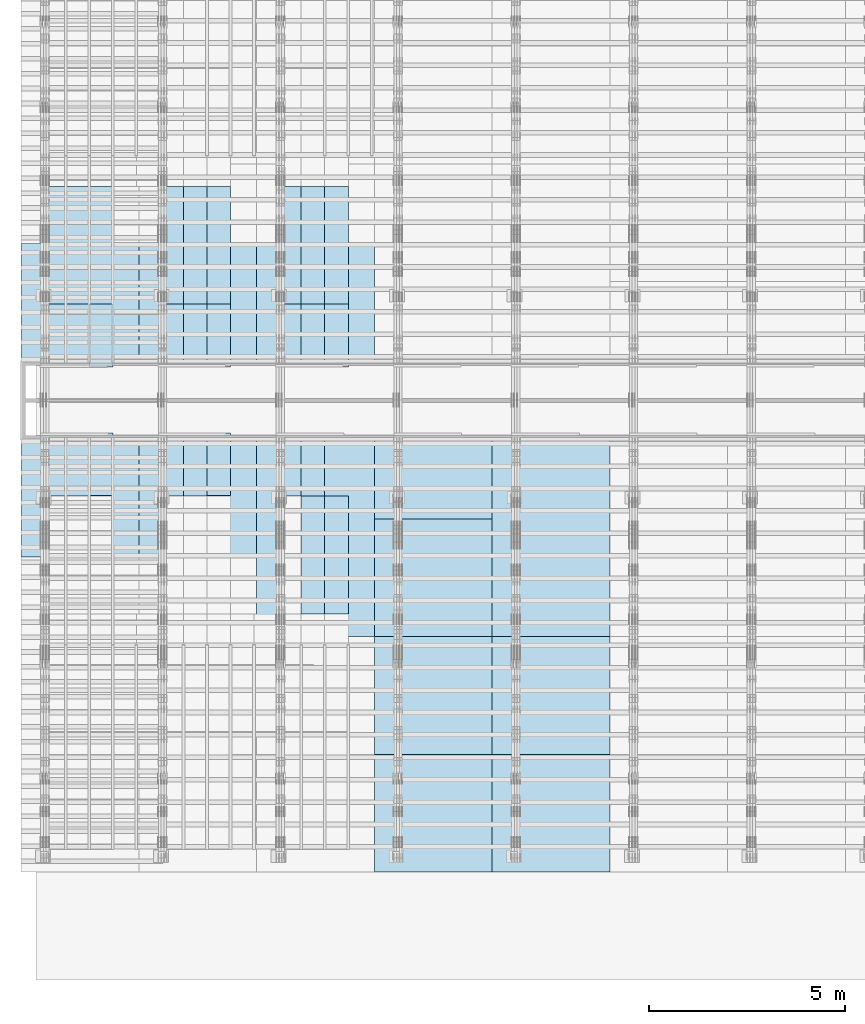
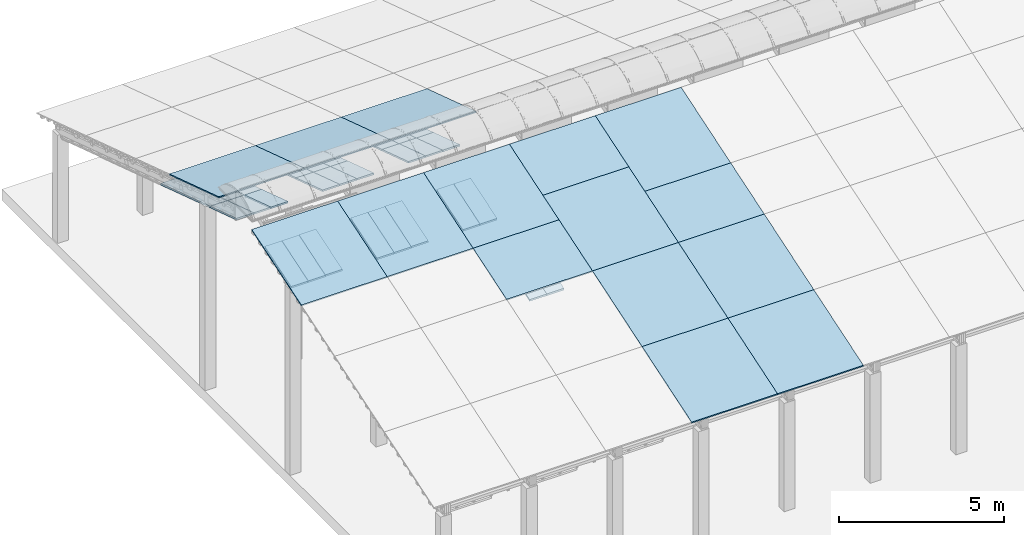
# One storey, part 6 of 385: 44 slabs, 44 elements without a shape of their own.
"""IFC2X3 building model written with IfcOpenShell, lengths in millimetres."""

from ifc_helpers import new_model, entity, si_unit, converted_unit, derived_unit, direction, frame, frame_2d, origin, place, context, subcontext, project, spatial, rectangle, extrude, material, layer, layer_set, element, aggregate, save


model = new_model("IFC2X3")

# Units and contexts
model_context = context("Model", 3, precision=0.01, world=origin(), true_north=direction((6.12303176911189e-17, 1.0)))
body_context = subcontext(model_context, "Body", "Model", "MODEL_VIEW")
ifc_project = project(units=[si_unit("LENGTHUNIT", "METRE", prefix="MILLI"), si_unit("AREAUNIT", "SQUARE_METRE"), si_unit("VOLUMEUNIT", "CUBIC_METRE"), converted_unit("PLANEANGLEUNIT", "DEGREE", entity("IfcRatioMeasure", 0.0174532925199433), si_unit("PLANEANGLEUNIT", "RADIAN"), dimensions=[0, 0, 0, 0, 0, 0, 0]), si_unit("MASSUNIT", "GRAM", prefix="KILO"), derived_unit("MASSDENSITYUNIT", [(si_unit("MASSUNIT", "GRAM", prefix="KILO"), 1), (si_unit("LENGTHUNIT", "METRE"), -3)]), si_unit("TIMEUNIT", "SECOND"), si_unit("FREQUENCYUNIT", "HERTZ"), si_unit("THERMODYNAMICTEMPERATUREUNIT", "DEGREE_CELSIUS"), derived_unit("THERMALTRANSMITTANCEUNIT", [(si_unit("MASSUNIT", "GRAM", prefix="KILO"), 1), (si_unit("THERMODYNAMICTEMPERATUREUNIT", "KELVIN"), -1), (si_unit("TIMEUNIT", "SECOND"), -3)]), derived_unit("VOLUMETRICFLOWRATEUNIT", [(si_unit("LENGTHUNIT", "METRE"), 3), (si_unit("TIMEUNIT", "SECOND"), -1)]), si_unit("ELECTRICCURRENTUNIT", "AMPERE"), si_unit("ELECTRICVOLTAGEUNIT", "VOLT"), si_unit("POWERUNIT", "WATT"), si_unit("FORCEUNIT", "NEWTON", prefix="KILO"), si_unit("ILLUMINANCEUNIT", "LUX"), si_unit("LUMINOUSFLUXUNIT", "LUMEN"), si_unit("LUMINOUSINTENSITYUNIT", "CANDELA"), derived_unit("USERDEFINED", [(si_unit("MASSUNIT", "GRAM", prefix="KILO"), -1), (si_unit("LENGTHUNIT", "METRE"), -2), (si_unit("TIMEUNIT", "SECOND"), 3), (si_unit("LUMINOUSFLUXUNIT", "LUMEN"), 1)]), derived_unit("LINEARVELOCITYUNIT", [(si_unit("LENGTHUNIT", "METRE"), 1), (si_unit("TIMEUNIT", "SECOND"), -1)]), si_unit("PRESSUREUNIT", "PASCAL"), derived_unit("USERDEFINED", [(si_unit("LENGTHUNIT", "METRE"), -2), (si_unit("MASSUNIT", "GRAM", prefix="KILO"), 1), (si_unit("TIMEUNIT", "SECOND"), -2)])], contexts=[model_context])

# Site, building, storey
site_placement = place(None, origin())
site = spatial("IfcSite", under=ifc_project, at=site_placement, CompositionType="ELEMENT")
building_placement = place(site_placement, origin())
building = spatial("IfcBuilding", under=site, at=building_placement, CompositionType="ELEMENT")
storey_placement = place(building_placement, origin())
storey = spatial("IfcBuildingStorey", under=building, at=storey_placement, Name="Default", CompositionType="ELEMENT", Elevation=0.0)

# Roof, slab
roof_1_placement = place(storey_placement, frame((-325.490958783843, 15713.9166481203, 3203.52447589904)))
roof_1 = element("IfcRoof", 1, at=roof_1_placement, inside=storey, ShapeType="NOTDEFINED")
ifc_material_1 = material()
ifc_layer_1 = layer(ifc_material_1, 40.0)
ifc_layer_set_1 = layer_set([ifc_layer_1])
slab_1_placement = place(roof_1_placement, origin())
slab_1 = element("IfcSlab", 2, at=slab_1_placement, material=ifc_layer_set_1, PredefinedType="ROOF", context=body_context, shape_type="SweptSolid", body=[
    extrude(rectangle(XDim=3154.3866727148, YDim=2999.99999999999, at=frame_2d((5.6843418860808e-13, 1.13686837721616e-12), x_axis=(0.0, 1.0))), frame((1500.0, 1500.0, 487.379544349359), z_axis=(0.0, 0.309016994374947, 0.951056516295154), x_axis=(1.0, 0.0, 0.0)), (0.0, -0.309016994374947, 0.951056516295154), 42.0584889695308),
])
aggregate(roof_1, [slab_1])

roof_2_placement = place(building_placement, frame((210.0, 17167.6676853402, 1763.02090616443)))
roof_2 = element("IfcRoof", 3, at=roof_2_placement, inside=storey, ShapeType="NOTDEFINED")
ifc_material_2 = material(Name="NLRS_n7_isolatie MegaPlus_Kingspan")
ifc_layer_2 = layer(ifc_material_2, 60.0)
ifc_layer_set_2 = layer_set([ifc_layer_2])
slab_2_placement = place(roof_2_placement, origin())
slab_2 = element("IfcSlab", 4, at=slab_2_placement, material=ifc_layer_set_2, PredefinedType="ROOF", context=body_context, shape_type="SweptSolid", body=[
    extrude(rectangle(XDim=600.0, YDim=3154.38667271481, at=frame_2d((0.0, 0.0), x_axis=(-1.0, 0.0))), frame((300.0, 1500.0, 487.379544349361), z_axis=(0.0, 0.309016994374947, 0.951056516295154), x_axis=(1.0, 0.0, 0.0)), (0.0, -0.309016994374947, 0.951056516295154), 63.087733454296),
])
aggregate(roof_2, [slab_2])

roof_3_placement = place(building_placement, frame((210.0, 15567.6676853402, 2737.77999486316)))
roof_3 = element("IfcRoof", 5, at=roof_3_placement, inside=storey, ShapeType="NOTDEFINED")
slab_3_placement = place(roof_3_placement, origin())
slab_3 = element("IfcSlab", 6, at=slab_3_placement, material=ifc_layer_set_2, PredefinedType="ROOF", context=body_context, shape_type="SweptSolid", body=[
    extrude(rectangle(XDim=600.0, YDim=1682.33955878123, at=frame_2d((-2.8421709430404e-14, 0.0), x_axis=(-1.0, 0.0))), frame((300.0, 800.0, 259.935756986325), z_axis=(0.0, 0.309016994374947, 0.951056516295154), x_axis=(1.0, 0.0, 0.0)), (0.0, -0.309016994374947, 0.951056516295154), 63.087733454296),
])
aggregate(roof_3, [slab_3])

roof_4_placement = place(storey_placement, frame((810.0, 17167.6676853402, 1763.02090616443)))
roof_4 = element("IfcRoof", 7, at=roof_4_placement, inside=storey, ShapeType="NOTDEFINED")
slab_4_placement = place(roof_4_placement, origin())
slab_4 = element("IfcSlab", 8, at=slab_4_placement, material=ifc_layer_set_2, PredefinedType="ROOF", context=body_context, shape_type="SweptSolid", body=[
    extrude(rectangle(XDim=600.0, YDim=3154.38667271481, at=frame_2d((0.0, 0.0), x_axis=(-1.0, 0.0))), frame((300.0, 1500.0, 487.379544349361), z_axis=(0.0, 0.309016994374947, 0.951056516295154), x_axis=(1.0, 0.0, 0.0)), (0.0, -0.309016994374947, 0.951056516295154), 63.087733454296),
])
aggregate(roof_4, [slab_4])

roof_5_placement = place(storey_placement, frame((810.0, 15567.6676853402, 2737.77999486316)))
roof_5 = element("IfcRoof", 9, at=roof_5_placement, inside=storey, ShapeType="NOTDEFINED")
slab_5_placement = place(roof_5_placement, origin())
slab_5 = element("IfcSlab", 10, at=slab_5_placement, material=ifc_layer_set_2, PredefinedType="ROOF", context=body_context, shape_type="SweptSolid", body=[
    extrude(rectangle(XDim=600.0, YDim=1682.33955878123, at=frame_2d((8.5265128291212e-14, 0.0), x_axis=(-1.0, 0.0))), frame((300.0, 800.0, 259.935756986325), z_axis=(0.0, 0.309016994374947, 0.951056516295154), x_axis=(1.0, 0.0, 0.0)), (0.0, -0.309016994374947, 0.951056516295154), 63.087733454296),
])
aggregate(roof_5, [slab_5])

roof_6_placement = place(storey_placement, frame((1410.0, 17167.6676853402, 1763.02090616443)))
roof_6 = element("IfcRoof", 11, at=roof_6_placement, inside=storey, ShapeType="NOTDEFINED")
slab_6_placement = place(roof_6_placement, origin())
slab_6 = element("IfcSlab", 12, at=slab_6_placement, material=ifc_layer_set_2, PredefinedType="ROOF", context=body_context, shape_type="SweptSolid", body=[
    extrude(rectangle(XDim=600.0, YDim=3154.38667271481, at=frame_2d((0.0, 0.0), x_axis=(-1.0, 0.0))), frame((300.0, 1500.0, 487.379544349361), z_axis=(0.0, 0.309016994374947, 0.951056516295154), x_axis=(1.0, 0.0, 0.0)), (0.0, -0.309016994374947, 0.951056516295154), 63.087733454296),
])
aggregate(roof_6, [slab_6])

roof_7_placement = place(storey_placement, frame((1410.0, 15565.4257355153, 2738.50844851925)))
roof_7 = element("IfcRoof", 13, at=roof_7_placement, inside=storey, ShapeType="NOTDEFINED")
slab_7_placement = place(roof_7_placement, origin())
slab_7 = element("IfcSlab", 14, at=slab_7_placement, material=ifc_layer_set_2, PredefinedType="ROOF", context=body_context, shape_type="SweptSolid", body=[
    extrude(rectangle(XDim=600.0, YDim=1682.33955878123, at=frame_2d((0.0, 0.0), x_axis=(-1.0, 0.0))), frame((300.0, 800.0, 259.935756986325), z_axis=(0.0, 0.309016994374947, 0.951056516295154), x_axis=(1.0, 0.0, 0.0)), (0.0, -0.309016994374947, 0.951056516295154), 63.087733454296),
])
aggregate(roof_7, [slab_7])

roof_8_placement = place(storey_placement, frame((210.0, 12272.3321452101, 2737.77999486316)))
roof_8 = element("IfcRoof", 15, at=roof_8_placement, inside=storey, ShapeType="NOTDEFINED")
slab_8_placement = place(roof_8_placement, origin())
slab_8 = element("IfcSlab", 16, at=slab_8_placement, material=ifc_layer_set_2, PredefinedType="ROOF", context=body_context, shape_type="SweptSolid", body=[
    extrude(rectangle(XDim=600.0, YDim=1682.33955878123, at=frame_2d((0.0, 0.0), x_axis=(-1.0, 0.0))), frame((300.0, 800.0, 259.935756986324), z_axis=(0.0, -0.309016994374947, 0.951056516295154), x_axis=(1.0, 0.0, 0.0)), (0.0, 0.309016994374947, 0.951056516295154), 63.087733454296),
])
aggregate(roof_8, [slab_8])

roof_9_placement = place(storey_placement, frame((810.0, 12272.3321452101, 2737.77999486316)))
roof_9 = element("IfcRoof", 17, at=roof_9_placement, inside=storey, ShapeType="NOTDEFINED")
slab_9_placement = place(roof_9_placement, origin())
slab_9 = element("IfcSlab", 18, at=slab_9_placement, material=ifc_layer_set_2, PredefinedType="ROOF", context=body_context, shape_type="SweptSolid", body=[
    extrude(rectangle(XDim=600.0, YDim=1682.33955878123, at=frame_2d((0.0, -1.13686837721616e-12), x_axis=(-1.0, 0.0))), frame((300.0, 800.0, 259.935756986326), z_axis=(0.0, -0.309016994374947, 0.951056516295154), x_axis=(1.0, 0.0, 0.0)), (0.0, 0.309016994374947, 0.951056516295154), 63.087733454296),
])
aggregate(roof_9, [slab_9])

roof_10_placement = place(storey_placement, frame((1410.0, 15565.4257355152, 2738.50844851925)))
roof_10 = element("IfcRoof", 19, at=roof_10_placement, inside=storey, ShapeType="NOTDEFINED")
slab_10_placement = place(roof_10_placement, origin())
slab_10 = element("IfcSlab", 20, at=slab_10_placement, material=ifc_layer_set_2, PredefinedType="ROOF", context=body_context, shape_type="SweptSolid", body=[
    extrude(rectangle(XDim=600.0, YDim=1682.33955878123, at=frame_2d((0.0, 0.0), x_axis=(-1.0, 0.0))), frame((300.0, 800.0, 259.935756986325), z_axis=(0.0, 0.309016994374947, 0.951056516295154), x_axis=(1.0, 0.0, 0.0)), (0.0, -0.309016994374947, 0.951056516295154), 63.087733454296),
])
aggregate(roof_10, [slab_10])

roof_11_placement = place(building_placement, frame((1410.0, 12284.9998024899, 2741.90128085392)))
roof_11 = element("IfcRoof", 21, at=roof_11_placement, inside=storey, ShapeType="NOTDEFINED")
slab_11_placement = place(roof_11_placement, origin())
slab_11 = element("IfcSlab", 22, at=slab_11_placement, material=ifc_layer_set_2, PredefinedType="ROOF", context=body_context, shape_type="SweptSolid", body=[
    extrude(rectangle(XDim=600.0, YDim=1682.33955878123, at=frame_2d((-1.13686837721616e-13, -1.13686837721616e-12), x_axis=(-1.0, 0.0))), frame((300.0, 800.0, 259.935756986326), z_axis=(0.0, -0.309016994374947, 0.951056516295154), x_axis=(1.0, 0.0, 0.0)), (0.0, 0.309016994374947, 0.951056516295154), 63.087733454296),
])
aggregate(roof_11, [slab_11])

roof_12_placement = place(building_placement, frame((-325.490958783843, 10724.9959924011, 3203.1710874096)))
roof_12 = element("IfcRoof", 23, at=roof_12_placement, inside=storey, ShapeType="NOTDEFINED")
slab_12_placement = place(roof_12_placement, origin())
slab_12 = element("IfcSlab", 24, at=slab_12_placement, material=ifc_layer_set_1, PredefinedType="ROOF", context=body_context, shape_type="SweptSolid", body=[
    extrude(rectangle(XDim=3154.3866727148, YDim=2999.99999999999, at=frame_2d((0.0, -1.02318153949454e-12), x_axis=(0.0, -1.0))), frame((1500.0, 1500.0, 487.379544349359), z_axis=(0.0, -0.309016994374947, 0.951056516295154), x_axis=(1.0, 0.0, 0.0)), (0.0, 0.309016994374947, 0.951056516295154), 42.0584889695308),
])
aggregate(roof_12, [slab_12])

roof_13_placement = place(storey_placement, frame((3210.0, 17167.6676853402, 1763.02090616443)))
roof_13 = element("IfcRoof", 25, at=roof_13_placement, inside=storey, ShapeType="NOTDEFINED")
slab_13_placement = place(roof_13_placement, origin())
slab_13 = element("IfcSlab", 26, at=slab_13_placement, material=ifc_layer_set_2, PredefinedType="ROOF", context=body_context, shape_type="SweptSolid", body=[
    extrude(rectangle(XDim=600.0, YDim=3154.38667271481, at=frame_2d((0.0, 0.0), x_axis=(-1.0, 0.0))), frame((300.0, 1500.0, 487.379544349361), z_axis=(0.0, 0.309016994374947, 0.951056516295154), x_axis=(1.0, 0.0, 0.0)), (0.0, -0.309016994374947, 0.951056516295154), 63.087733454296),
])
aggregate(roof_13, [slab_13])

roof_14_placement = place(storey_placement, frame((3210.0, 15567.6676853402, 2737.77999486316)))
roof_14 = element("IfcRoof", 27, at=roof_14_placement, inside=storey, ShapeType="NOTDEFINED")
slab_14_placement = place(roof_14_placement, origin())
slab_14 = element("IfcSlab", 28, at=slab_14_placement, material=ifc_layer_set_2, PredefinedType="ROOF", context=body_context, shape_type="SweptSolid", body=[
    extrude(rectangle(XDim=600.0, YDim=1682.33955878123, at=frame_2d((0.0, 0.0), x_axis=(-1.0, 0.0))), frame((300.0, 800.0, 259.935756986325), z_axis=(0.0, 0.309016994374947, 0.951056516295154), x_axis=(1.0, 0.0, 0.0)), (0.0, -0.309016994374947, 0.951056516295154), 63.087733454296),
])
aggregate(roof_14, [slab_14])

roof_15_placement = place(storey_placement, frame((3810.0, 17167.6676853402, 1763.02090616443)))
roof_15 = element("IfcRoof", 29, at=roof_15_placement, inside=storey, ShapeType="NOTDEFINED")
slab_15_placement = place(roof_15_placement, origin())
slab_15 = element("IfcSlab", 30, at=slab_15_placement, material=ifc_layer_set_2, PredefinedType="ROOF", context=body_context, shape_type="SweptSolid", body=[
    extrude(rectangle(XDim=600.0, YDim=3154.38667271481, at=frame_2d((0.0, 0.0), x_axis=(-1.0, 0.0))), frame((300.0, 1500.0, 487.379544349361), z_axis=(0.0, 0.309016994374947, 0.951056516295154), x_axis=(1.0, 0.0, 0.0)), (0.0, -0.309016994374947, 0.951056516295154), 63.087733454296),
])
aggregate(roof_15, [slab_15])

roof_16_placement = place(storey_placement, frame((3810.0, 15567.6676853402, 2737.77999486316)))
roof_16 = element("IfcRoof", 31, at=roof_16_placement, inside=storey, ShapeType="NOTDEFINED")
slab_16_placement = place(roof_16_placement, origin())
slab_16 = element("IfcSlab", 32, at=slab_16_placement, material=ifc_layer_set_2, PredefinedType="ROOF", context=body_context, shape_type="SweptSolid", body=[
    extrude(rectangle(XDim=600.0, YDim=1682.33955878123, at=frame_2d((0.0, 0.0), x_axis=(-1.0, 0.0))), frame((300.0, 800.0, 259.935756986325), z_axis=(0.0, 0.309016994374947, 0.951056516295154), x_axis=(1.0, 0.0, 0.0)), (0.0, -0.309016994374947, 0.951056516295154), 63.087733454296),
])
aggregate(roof_16, [slab_16])

roof_17_placement = place(storey_placement, frame((4410.0, 17167.6676853402, 1763.02090616443)))
roof_17 = element("IfcRoof", 33, at=roof_17_placement, inside=storey, ShapeType="NOTDEFINED")
slab_17_placement = place(roof_17_placement, origin())
slab_17 = element("IfcSlab", 34, at=slab_17_placement, material=ifc_layer_set_2, PredefinedType="ROOF", context=body_context, shape_type="SweptSolid", body=[
    extrude(rectangle(XDim=600.000000000001, YDim=3154.38667271481, at=frame_2d((-2.8421709430404e-13, 0.0), x_axis=(-1.0, 0.0))), frame((300.0, 1500.0, 487.379544349361), z_axis=(0.0, 0.309016994374947, 0.951056516295154), x_axis=(1.0, 0.0, 0.0)), (0.0, -0.309016994374947, 0.951056516295154), 63.087733454296),
])
aggregate(roof_17, [slab_17])

roof_18_placement = place(storey_placement, frame((3210.0, 12272.3321452101, 2737.77999486316)))
roof_18 = element("IfcRoof", 35, at=roof_18_placement, inside=storey, ShapeType="NOTDEFINED")
slab_18_placement = place(roof_18_placement, origin())
slab_18 = element("IfcSlab", 36, at=slab_18_placement, material=ifc_layer_set_2, PredefinedType="ROOF", context=body_context, shape_type="SweptSolid", body=[
    extrude(rectangle(XDim=600.0, YDim=1682.33955878123, at=frame_2d((0.0, -1.13686837721616e-12), x_axis=(-1.0, 0.0))), frame((300.0, 800.0, 259.935756986325), z_axis=(0.0, -0.309016994374947, 0.951056516295154), x_axis=(1.0, 0.0, 0.0)), (0.0, 0.309016994374947, 0.951056516295154), 63.087733454296),
])
aggregate(roof_18, [slab_18])

roof_19_placement = place(storey_placement, frame((3810.0, 12272.3321452101, 2737.77999486316)))
roof_19 = element("IfcRoof", 37, at=roof_19_placement, inside=storey, ShapeType="NOTDEFINED")
slab_19_placement = place(roof_19_placement, origin())
slab_19 = element("IfcSlab", 38, at=slab_19_placement, material=ifc_layer_set_2, PredefinedType="ROOF", context=body_context, shape_type="SweptSolid", body=[
    extrude(rectangle(XDim=600.0, YDim=1682.33955878123, at=frame_2d((0.0, -1.13686837721616e-12), x_axis=(-1.0, 0.0))), frame((300.0, 800.0, 259.935756986326), z_axis=(0.0, -0.309016994374947, 0.951056516295154), x_axis=(1.0, 0.0, 0.0)), (0.0, 0.309016994374947, 0.951056516295154), 63.087733454296),
])
aggregate(roof_19, [slab_19])

roof_20_placement = place(storey_placement, frame((4410.0, 15565.4257355152, 2738.50844851925)))
roof_20 = element("IfcRoof", 39, at=roof_20_placement, inside=storey, ShapeType="NOTDEFINED")
slab_20_placement = place(roof_20_placement, origin())
slab_20 = element("IfcSlab", 40, at=slab_20_placement, material=ifc_layer_set_2, PredefinedType="ROOF", context=body_context, shape_type="SweptSolid", body=[
    extrude(rectangle(XDim=600.000000000001, YDim=1682.33955878123, at=frame_2d((2.55795384873636e-13, 0.0), x_axis=(-1.0, 0.0))), frame((300.0, 800.0, 259.935756986325), z_axis=(0.0, 0.309016994374947, 0.951056516295154), x_axis=(1.0, 0.0, 0.0)), (0.0, -0.309016994374947, 0.951056516295154), 63.087733454296),
])
aggregate(roof_20, [slab_20])

roof_21_placement = place(storey_placement, frame((4410.0, 12284.9998024899, 2741.90128085392)))
roof_21 = element("IfcRoof", 41, at=roof_21_placement, inside=storey, ShapeType="NOTDEFINED")
slab_21_placement = place(roof_21_placement, origin())
slab_21 = element("IfcSlab", 42, at=slab_21_placement, material=ifc_layer_set_2, PredefinedType="ROOF", context=body_context, shape_type="SweptSolid", body=[
    extrude(rectangle(XDim=600.0, YDim=1682.33955878123, at=frame_2d((0.0, -1.13686837721616e-12), x_axis=(-1.0, 0.0))), frame((300.0, 800.0, 259.935756986326), z_axis=(0.0, -0.309016994374947, 0.951056516295154), x_axis=(1.0, 0.0, 0.0)), (0.0, 0.309016994374947, 0.951056516295154), 63.087733454296),
])
aggregate(roof_21, [slab_21])

roof_22_placement = place(storey_placement, frame((6210.0, 17167.6676853402, 1763.02090616443)))
roof_22 = element("IfcRoof", 43, at=roof_22_placement, inside=storey, ShapeType="NOTDEFINED")
slab_22_placement = place(roof_22_placement, origin())
slab_22 = element("IfcSlab", 44, at=slab_22_placement, material=ifc_layer_set_2, PredefinedType="ROOF", context=body_context, shape_type="SweptSolid", body=[
    extrude(rectangle(XDim=600.0, YDim=3154.38667271481, at=frame_2d((0.0, 0.0), x_axis=(-1.0, 0.0))), frame((300.0, 1500.0, 487.379544349361), z_axis=(0.0, 0.309016994374947, 0.951056516295154), x_axis=(1.0, 0.0, 0.0)), (0.0, -0.309016994374947, 0.951056516295154), 63.087733454296),
])
aggregate(roof_22, [slab_22])

roof_23_placement = place(storey_placement, frame((6210.0, 15567.6676853402, 2737.77999486316)))
roof_23 = element("IfcRoof", 45, at=roof_23_placement, inside=storey, ShapeType="NOTDEFINED")
slab_23_placement = place(roof_23_placement, origin())
slab_23 = element("IfcSlab", 46, at=slab_23_placement, material=ifc_layer_set_2, PredefinedType="ROOF", context=body_context, shape_type="SweptSolid", body=[
    extrude(rectangle(XDim=600.0, YDim=1682.33955878123, at=frame_2d((-5.40012479177676e-13, 0.0), x_axis=(-1.0, 0.0))), frame((300.0, 800.0, 259.935756986325), z_axis=(0.0, 0.309016994374947, 0.951056516295154), x_axis=(1.0, 0.0, 0.0)), (0.0, -0.309016994374947, 0.951056516295154), 63.087733454296),
])
aggregate(roof_23, [slab_23])

roof_24_placement = place(storey_placement, frame((6810.0, 17167.6676853402, 1763.02090616443)))
roof_24 = element("IfcRoof", 47, at=roof_24_placement, inside=storey, ShapeType="NOTDEFINED")
slab_24_placement = place(roof_24_placement, origin())
slab_24 = element("IfcSlab", 48, at=slab_24_placement, material=ifc_layer_set_2, PredefinedType="ROOF", context=body_context, shape_type="SweptSolid", body=[
    extrude(rectangle(XDim=600.0, YDim=3154.38667271481, at=frame_2d((0.0, 0.0), x_axis=(-1.0, 0.0))), frame((300.0, 1500.0, 487.379544349361), z_axis=(0.0, 0.309016994374947, 0.951056516295154), x_axis=(1.0, 0.0, 0.0)), (0.0, -0.309016994374947, 0.951056516295154), 63.087733454296),
])
aggregate(roof_24, [slab_24])

roof_25_placement = place(storey_placement, frame((6810.0, 15567.6676853402, 2737.77999486316)))
roof_25 = element("IfcRoof", 49, at=roof_25_placement, inside=storey, ShapeType="NOTDEFINED")
slab_25_placement = place(roof_25_placement, origin())
slab_25 = element("IfcSlab", 50, at=slab_25_placement, material=ifc_layer_set_2, PredefinedType="ROOF", context=body_context, shape_type="SweptSolid", body=[
    extrude(rectangle(XDim=600.0, YDim=1682.33955878123, at=frame_2d((-5.40012479177676e-13, 0.0), x_axis=(-1.0, 0.0))), frame((300.0, 800.0, 259.935756986325), z_axis=(0.0, 0.309016994374947, 0.951056516295154), x_axis=(1.0, 0.0, 0.0)), (0.0, -0.309016994374947, 0.951056516295154), 63.087733454296),
])
aggregate(roof_25, [slab_25])

roof_26_placement = place(storey_placement, frame((7410.0, 17167.6676853402, 1763.02090616443)))
roof_26 = element("IfcRoof", 51, at=roof_26_placement, inside=storey, ShapeType="NOTDEFINED")
slab_26_placement = place(roof_26_placement, origin())
slab_26 = element("IfcSlab", 52, at=slab_26_placement, material=ifc_layer_set_2, PredefinedType="ROOF", context=body_context, shape_type="SweptSolid", body=[
    extrude(rectangle(XDim=600.0, YDim=3154.38667271481, at=frame_2d((0.0, 0.0), x_axis=(-1.0, 0.0))), frame((300.0, 1500.0, 487.379544349361), z_axis=(0.0, 0.309016994374947, 0.951056516295154), x_axis=(1.0, 0.0, 0.0)), (0.0, -0.309016994374947, 0.951056516295154), 63.087733454296),
])
aggregate(roof_26, [slab_26])

roof_27_placement = place(storey_placement, frame((6210.0, 12272.3321452101, 2737.77999486316)))
roof_27 = element("IfcRoof", 53, at=roof_27_placement, inside=storey, ShapeType="NOTDEFINED")
slab_27_placement = place(roof_27_placement, origin())
slab_27 = element("IfcSlab", 54, at=slab_27_placement, material=ifc_layer_set_2, PredefinedType="ROOF", context=body_context, shape_type="SweptSolid", body=[
    extrude(rectangle(XDim=599.999999999999, YDim=1682.33955878123, at=frame_2d((5.40012479177676e-13, 0.0), x_axis=(-1.0, 0.0))), frame((300.0, 800.0, 259.935756986324), z_axis=(0.0, -0.309016994374947, 0.951056516295154), x_axis=(1.0, 0.0, 0.0)), (0.0, 0.309016994374947, 0.951056516295154), 63.087733454296),
])
aggregate(roof_27, [slab_27])

roof_28_placement = place(storey_placement, frame((6810.0, 9272.33214521008, 1763.02090616443)))
roof_28 = element("IfcRoof", 55, at=roof_28_placement, inside=storey, ShapeType="NOTDEFINED")
slab_28_placement = place(roof_28_placement, origin())
slab_28 = element("IfcSlab", 56, at=slab_28_placement, material=ifc_layer_set_2, PredefinedType="ROOF", context=body_context, shape_type="SweptSolid", body=[
    extrude(rectangle(XDim=600.000000000001, YDim=3154.38667271481, at=frame_2d((0.0, 0.0), x_axis=(-1.0, 0.0))), frame((300.0, 1500.0, 487.379544349361), z_axis=(0.0, -0.309016994374947, 0.951056516295154), x_axis=(1.0, 0.0, 0.0)), (0.0, 0.309016994374947, 0.951056516295154), 63.087733454296),
])
aggregate(roof_28, [slab_28])

roof_29_placement = place(storey_placement, frame((6810.0, 12272.3321452101, 2737.77999486316)))
roof_29 = element("IfcRoof", 57, at=roof_29_placement, inside=storey, ShapeType="NOTDEFINED")
slab_29_placement = place(roof_29_placement, origin())
slab_29 = element("IfcSlab", 58, at=slab_29_placement, material=ifc_layer_set_2, PredefinedType="ROOF", context=body_context, shape_type="SweptSolid", body=[
    extrude(rectangle(XDim=599.999999999999, YDim=1682.33955878123, at=frame_2d((5.40012479177676e-13, 5.6843418860808e-14), x_axis=(-1.0, 0.0))), frame((300.0, 800.0, 259.935756986325), z_axis=(0.0, -0.309016994374947, 0.951056516295154), x_axis=(1.0, 0.0, 0.0)), (0.0, 0.309016994374947, 0.951056516295154), 63.087733454296),
])
aggregate(roof_29, [slab_29])

roof_30_placement = place(storey_placement, frame((7410.0, 9272.33214521007, 1763.02090616443)))
roof_30 = element("IfcRoof", 59, at=roof_30_placement, inside=storey, ShapeType="NOTDEFINED")
slab_30_placement = place(roof_30_placement, origin())
slab_30 = element("IfcSlab", 60, at=slab_30_placement, material=ifc_layer_set_2, PredefinedType="ROOF", context=body_context, shape_type="SweptSolid", body=[
    extrude(rectangle(XDim=600.000000000001, YDim=3154.38667271482, at=frame_2d((0.0, 0.0), x_axis=(-1.0, 0.0))), frame((300.0, 1500.0, 487.379544349361), z_axis=(0.0, -0.309016994374947, 0.951056516295154), x_axis=(1.0, 0.0, 0.0)), (0.0, 0.309016994374947, 0.951056516295154), 63.087733454296),
])
aggregate(roof_30, [slab_30])

roof_31_placement = place(storey_placement, frame((7410.0, 15565.4257355152, 2738.50844851925)))
roof_31 = element("IfcRoof", 61, at=roof_31_placement, inside=storey, ShapeType="NOTDEFINED")
slab_31_placement = place(roof_31_placement, origin())
slab_31 = element("IfcSlab", 62, at=slab_31_placement, material=ifc_layer_set_2, PredefinedType="ROOF", context=body_context, shape_type="SweptSolid", body=[
    extrude(rectangle(XDim=600.0, YDim=1682.33955878123, at=frame_2d((-5.40012479177676e-13, 0.0), x_axis=(-1.0, 0.0))), frame((300.0, 800.0, 259.935756986325), z_axis=(0.0, 0.309016994374947, 0.951056516295154), x_axis=(1.0, 0.0, 0.0)), (0.0, -0.309016994374947, 0.951056516295154), 63.087733454296),
])
aggregate(roof_31, [slab_31])

roof_32_placement = place(storey_placement, frame((2674.50904121615, 15713.9166481203, 3203.52447589904)))
roof_32 = element("IfcRoof", 63, at=roof_32_placement, inside=storey, ShapeType="NOTDEFINED")
slab_32_placement = place(roof_32_placement, origin())
slab_32 = element("IfcSlab", 64, at=slab_32_placement, material=ifc_layer_set_1, PredefinedType="ROOF", context=body_context, shape_type="SweptSolid", body=[
    extrude(rectangle(XDim=3154.3866727148, YDim=2999.99999999999, at=frame_2d((5.6843418860808e-13, 1.13686837721616e-12), x_axis=(0.0, 1.0))), frame((1500.0, 1500.0, 487.379544349359), z_axis=(0.0, 0.309016994374947, 0.951056516295154), x_axis=(1.0, 0.0, 0.0)), (0.0, -0.309016994374947, 0.951056516295154), 42.0584889695308),
])
aggregate(roof_32, [slab_32])

roof_33_placement = place(storey_placement, frame((2674.50904121614, 10724.9959924011, 3203.1710874096)))
roof_33 = element("IfcRoof", 65, at=roof_33_placement, inside=storey, ShapeType="NOTDEFINED")
slab_33_placement = place(roof_33_placement, origin())
slab_33 = element("IfcSlab", 66, at=slab_33_placement, material=ifc_layer_set_1, PredefinedType="ROOF", context=body_context, shape_type="SweptSolid", body=[
    extrude(rectangle(XDim=3154.3866727148, YDim=2999.99999999999, at=frame_2d((0.0, 0.0), x_axis=(0.0, -1.0))), frame((1500.0, 1500.0, 487.379544349359), z_axis=(0.0, -0.309016994374947, 0.951056516295154), x_axis=(1.0, 0.0, 0.0)), (0.0, 0.309016994374947, 0.951056516295154), 42.0584889695308),
])
aggregate(roof_33, [slab_33])

roof_34_placement = place(storey_placement, frame((5674.50904121614, 8697.55668997143, 2544.4161251335)))
roof_34 = element("IfcRoof", 67, at=roof_34_placement, inside=storey, ShapeType="NOTDEFINED")
slab_34_placement = place(roof_34_placement, origin())
slab_34 = element("IfcSlab", 68, at=slab_34_placement, material=ifc_layer_set_1, PredefinedType="ROOF", context=body_context, shape_type="SweptSolid", body=[
    extrude(rectangle(XDim=3154.3866727148, YDim=2999.99999999999, at=frame_2d((0.0, -1.02318153949454e-12), x_axis=(0.0, -1.0))), frame((1500.0, 1500.0, 487.379544349359), z_axis=(0.0, -0.309016994374947, 0.951056516295154), x_axis=(1.0, 0.0, 0.0)), (0.0, 0.309016994374947, 0.951056516295154), 42.0584889695308),
])
aggregate(roof_34, [slab_34])

roof_35_placement = place(storey_placement, frame((5674.50904121614, 15713.9166481203, 3203.52447589904)))
roof_35 = element("IfcRoof", 69, at=roof_35_placement, inside=storey, ShapeType="NOTDEFINED")
slab_35_placement = place(roof_35_placement, origin())
slab_35 = element("IfcSlab", 70, at=slab_35_placement, material=ifc_layer_set_1, PredefinedType="ROOF", context=body_context, shape_type="SweptSolid", body=[
    extrude(rectangle(XDim=3154.3866727148, YDim=2999.99999999999, at=frame_2d((5.6843418860808e-13, 1.13686837721616e-12), x_axis=(0.0, 1.0))), frame((1500.0, 1500.0, 487.379544349359), z_axis=(0.0, 0.309016994374947, 0.951056516295154), x_axis=(1.0, 0.0, 0.0)), (0.0, -0.309016994374947, 0.951056516295154), 42.0584889695308),
])
aggregate(roof_35, [slab_35])

roof_36_placement = place(storey_placement, frame((5674.50904121614, 10724.9959924011, 3203.1710874096)))
roof_36 = element("IfcRoof", 71, at=roof_36_placement, inside=storey, ShapeType="NOTDEFINED")
slab_36_placement = place(roof_36_placement, origin())
slab_36 = element("IfcSlab", 72, at=slab_36_placement, material=ifc_layer_set_1, PredefinedType="ROOF", context=body_context, shape_type="SweptSolid", body=[
    extrude(rectangle(XDim=3154.3866727148, YDim=2999.99999999999, at=frame_2d((0.0, 0.0), x_axis=(0.0, -1.0))), frame((1500.0, 1500.0, 487.379544349359), z_axis=(0.0, -0.309016994374947, 0.951056516295154), x_axis=(1.0, 0.0, 0.0)), (0.0, 0.309016994374947, 0.951056516295154), 42.0584889695308),
])
aggregate(roof_36, [slab_36])

roof_37_placement = place(storey_placement, frame((8674.50904121611, 2697.55668997141, 594.897947736069)))
roof_37 = element("IfcRoof", 73, at=roof_37_placement, inside=storey, ShapeType="NOTDEFINED")
slab_37_placement = place(roof_37_placement, origin())
slab_37 = element("IfcSlab", 74, at=slab_37_placement, material=ifc_layer_set_1, PredefinedType="ROOF", context=body_context, shape_type="SweptSolid", body=[
    extrude(rectangle(XDim=3154.3866727148, YDim=2999.99999999999, at=frame_2d((0.0, 5.6843418860808e-13), x_axis=(0.0, -1.0))), frame((1500.0, 1500.0, 487.379544349359), z_axis=(0.0, -0.309016994374947, 0.951056516295154), x_axis=(1.0, 0.0, 0.0)), (0.0, 0.309016994374947, 0.951056516295154), 42.0584889695306),
])
aggregate(roof_37, [slab_37])

roof_38_placement = place(storey_placement, frame((8674.50904121613, 5697.55668997142, 1569.65703643478)))
roof_38 = element("IfcRoof", 75, at=roof_38_placement, inside=storey, ShapeType="NOTDEFINED")
slab_38_placement = place(roof_38_placement, origin())
slab_38 = element("IfcSlab", 76, at=slab_38_placement, material=ifc_layer_set_1, PredefinedType="ROOF", context=body_context, shape_type="SweptSolid", body=[
    extrude(rectangle(XDim=3154.3866727148, YDim=2999.99999999999, at=frame_2d((0.0, 6.82121026329696e-13), x_axis=(0.0, -1.0))), frame((1500.0, 1500.0, 487.379544349359), z_axis=(0.0, -0.309016994374947, 0.951056516295154), x_axis=(1.0, 0.0, 0.0)), (0.0, 0.309016994374947, 0.951056516295154), 42.0584889695306),
])
aggregate(roof_38, [slab_38])

roof_39_placement = place(storey_placement, frame((8674.50904121613, 8697.55668997142, 2544.4161251335)))
roof_39 = element("IfcRoof", 77, at=roof_39_placement, inside=storey, ShapeType="NOTDEFINED")
slab_39_placement = place(roof_39_placement, origin())
slab_39 = element("IfcSlab", 78, at=slab_39_placement, material=ifc_layer_set_1, PredefinedType="ROOF", context=body_context, shape_type="SweptSolid", body=[
    extrude(rectangle(XDim=3154.3866727148, YDim=2999.99999999999, at=frame_2d((0.0, 6.82121026329696e-13), x_axis=(0.0, -1.0))), frame((1500.0, 1500.0, 487.379544349359), z_axis=(0.0, -0.309016994374947, 0.951056516295154), x_axis=(1.0, 0.0, 0.0)), (0.0, 0.309016994374947, 0.951056516295154), 42.0584889695308),
])
aggregate(roof_39, [slab_39])

roof_40_placement = place(storey_placement, frame((8674.50904121613, 10724.9959924011, 3203.1710874096)))
roof_40 = element("IfcRoof", 79, at=roof_40_placement, inside=storey, ShapeType="NOTDEFINED")
slab_40_placement = place(roof_40_placement, origin())
slab_40 = element("IfcSlab", 80, at=slab_40_placement, material=ifc_layer_set_1, PredefinedType="ROOF", context=body_context, shape_type="SweptSolid", body=[
    extrude(rectangle(XDim=3154.3866727148, YDim=2999.99999999999, at=frame_2d((0.0, 0.0), x_axis=(0.0, -1.0))), frame((1500.0, 1500.0, 487.379544349359), z_axis=(0.0, -0.309016994374947, 0.951056516295154), x_axis=(1.0, 0.0, 0.0)), (0.0, 0.309016994374947, 0.951056516295154), 42.0584889695308),
])
aggregate(roof_40, [slab_40])

roof_41_placement = place(storey_placement, frame((11674.5090412161, 2697.5566899714, 594.897947736069)))
roof_41 = element("IfcRoof", 81, at=roof_41_placement, inside=storey, ShapeType="NOTDEFINED")
slab_41_placement = place(roof_41_placement, origin())
slab_41 = element("IfcSlab", 82, at=slab_41_placement, material=ifc_layer_set_1, PredefinedType="ROOF", context=body_context, shape_type="SweptSolid", body=[
    extrude(rectangle(XDim=3154.3866727148, YDim=2999.99999999999, at=frame_2d((0.0, 0.0), x_axis=(0.0, -1.0))), frame((1500.0, 1500.0, 487.379544349359), z_axis=(0.0, -0.309016994374947, 0.951056516295154), x_axis=(1.0, 0.0, 0.0)), (0.0, 0.309016994374947, 0.951056516295154), 42.0584889695306),
])
aggregate(roof_41, [slab_41])

roof_42_placement = place(storey_placement, frame((11674.5090412161, 5697.55668997141, 1569.65703643478)))
roof_42 = element("IfcRoof", 83, at=roof_42_placement, inside=storey, ShapeType="NOTDEFINED")
slab_42_placement = place(roof_42_placement, origin())
slab_42 = element("IfcSlab", 84, at=slab_42_placement, material=ifc_layer_set_1, PredefinedType="ROOF", context=body_context, shape_type="SweptSolid", body=[
    extrude(rectangle(XDim=3154.3866727148, YDim=2999.99999999999, at=frame_2d((0.0, 1.13686837721616e-13), x_axis=(0.0, -1.0))), frame((1500.0, 1500.0, 487.379544349359), z_axis=(0.0, -0.309016994374947, 0.951056516295154), x_axis=(1.0, 0.0, 0.0)), (0.0, 0.309016994374947, 0.951056516295154), 42.0584889695306),
])
aggregate(roof_42, [slab_42])

roof_43_placement = place(storey_placement, frame((11674.5090412161, 8697.55668997141, 2544.4161251335)))
roof_43 = element("IfcRoof", 85, at=roof_43_placement, inside=storey, ShapeType="NOTDEFINED")
slab_43_placement = place(roof_43_placement, origin())
slab_43 = element("IfcSlab", 86, at=slab_43_placement, material=ifc_layer_set_1, PredefinedType="ROOF", context=body_context, shape_type="SweptSolid", body=[
    extrude(rectangle(XDim=3154.3866727148, YDim=2999.99999999999, at=frame_2d((0.0, 0.0), x_axis=(0.0, -1.0))), frame((1500.0, 1500.0, 487.379544349359), z_axis=(0.0, -0.309016994374947, 0.951056516295154), x_axis=(1.0, 0.0, 0.0)), (0.0, 0.309016994374947, 0.951056516295154), 42.0584889695308),
])
aggregate(roof_43, [slab_43])

roof_44_placement = place(storey_placement, frame((11674.5090412161, 10724.9959924011, 3203.1710874096)))
roof_44 = element("IfcRoof", 87, at=roof_44_placement, inside=storey, ShapeType="NOTDEFINED")
slab_44_placement = place(roof_44_placement, origin())
slab_44 = element("IfcSlab", 88, at=slab_44_placement, material=ifc_layer_set_1, PredefinedType="ROOF", context=body_context, shape_type="SweptSolid", body=[
    extrude(rectangle(XDim=3154.3866727148, YDim=2999.99999999999, at=frame_2d((0.0, 0.0), x_axis=(0.0, -1.0))), frame((1500.0, 1500.0, 487.379544349359), z_axis=(0.0, -0.309016994374947, 0.951056516295154), x_axis=(1.0, 0.0, 0.0)), (0.0, 0.309016994374947, 0.951056516295154), 42.0584889695308),
])
aggregate(roof_44, [slab_44])

save(model, "model.ifc")
